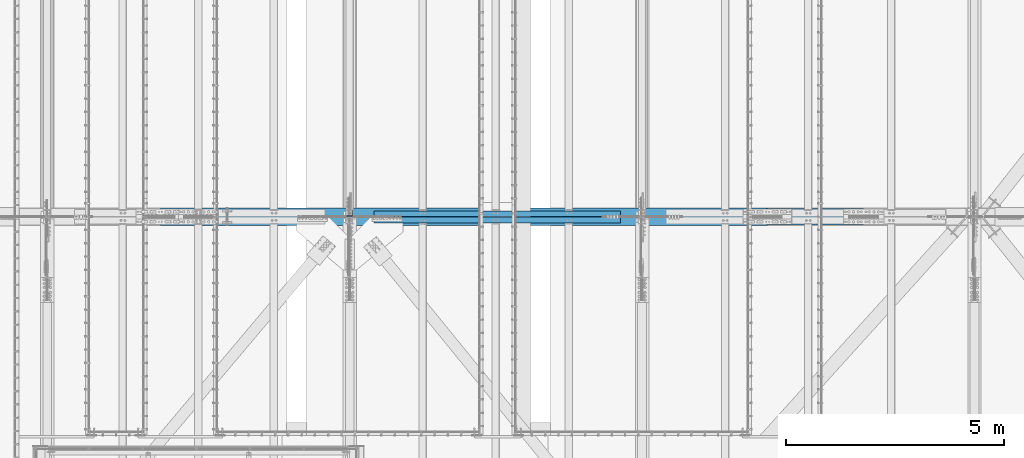
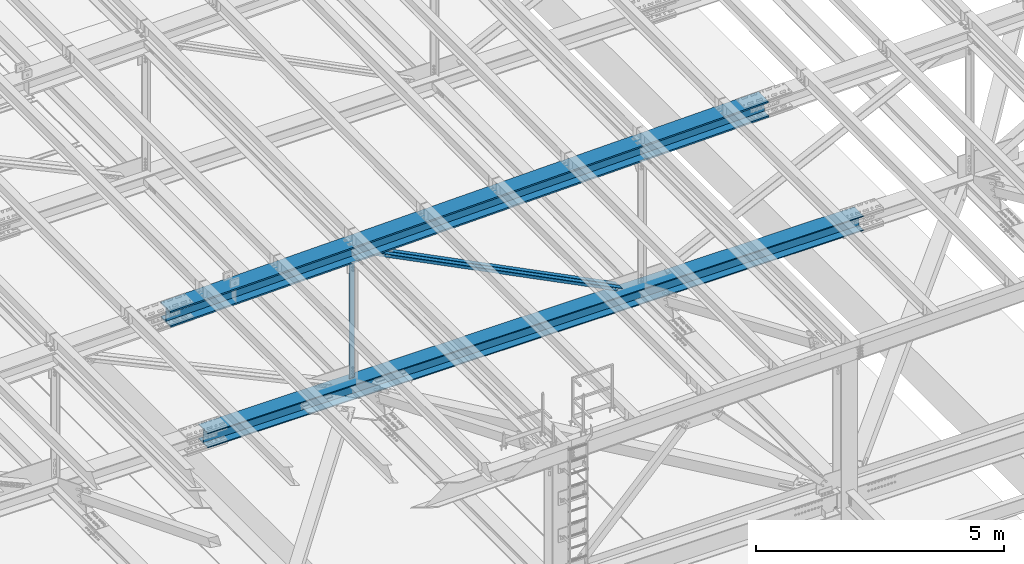
# One storey, part 1825 of 3843: 3 beams, 2 members, 5 elements without a shape of their own.
"""IFC2X3 building model written with IfcOpenShell, lengths in millimetres."""

from ifc_helpers import new_model, si_unit, frame, origin_with_axes, place, context, subcontext, project, spatial, faceted_brep, material, type_object, element, aggregate, save


model = new_model("IFC2X3")

# Units and contexts
model_context = context("Model", 3, precision=1e-05, world=origin_with_axes())
body_context = subcontext(model_context, "Body", "Model", "MODEL_VIEW")
ifc_project = project(units=[si_unit("LENGTHUNIT", "METRE", prefix="MILLI"), si_unit("AREAUNIT", "SQUARE_METRE"), si_unit("VOLUMEUNIT", "CUBIC_METRE"), si_unit("MASSUNIT", "GRAM", prefix="KILO"), si_unit("TIMEUNIT", "SECOND"), si_unit("PLANEANGLEUNIT", "RADIAN"), si_unit("SOLIDANGLEUNIT", "STERADIAN"), si_unit("THERMODYNAMICTEMPERATUREUNIT", "DEGREE_CELSIUS"), si_unit("LUMINOUSINTENSITYUNIT", "LUMEN")], contexts=[model_context])

# Site, building, storey
site_placement = place(None, origin_with_axes())
site = spatial("IfcSite", under=ifc_project, at=site_placement, CompositionType="ELEMENT")
building_placement = place(site_placement, origin_with_axes())
building = spatial("IfcBuilding", under=site, at=building_placement, Name="Undefined", CompositionType="ELEMENT")
storey_placement = place(building_placement, origin_with_axes())
storey = spatial("IfcBuildingStorey", under=building, at=storey_placement, Name="Undefined", CompositionType="ELEMENT", Elevation=0.0)

# Assembly, beam
assembly_1_placement = place(storey_placement, origin_with_axes())
assembly_1 = element("IfcElementAssembly", 1, at=assembly_1_placement, inside=storey, Name="BEAM", AssemblyPlace="NOTDEFINED", PredefinedType="RIGID_FRAME")
ifc_material_1 = material(Name="STEEL/A992")
beam_type_1 = type_object("IfcBeamType", Name="W14X193", PredefinedType="NOTDEFINED")
beam_1_placement = place(assembly_1_placement, frame((51591.6587020663, 33845.5, 45546.4074801041), z_axis=(-0.0216342480057937, 0.0, 0.999765952267441), x_axis=(0.999765952267441, 0.0, 0.0216342480057898)))
beam_1 = element("IfcBeam", 2, at=beam_1_placement, type_object=beam_type_1, material=ifc_material_1, Name="BEAM", ObjectType="W14X193", context=body_context, shape_type="Brep", body=[
    faceted_brep([(6.34999999676074, 200.025000000001, -196.850000000573), (6.3499999967753, 200.025000000001, -160.337500000467), (13916.1085202669, 200.025000000001, -160.337499982867), (13916.1085202304, 200.025000000001, -196.849999982958), (6.3499999967753, 11.1125000000029, -160.337500000467), (13916.1085202669, 11.1125000000029, -160.337499982867), (6.34999999676074, 11.1125000000029, 160.337500000445), (13916.1085205875, 11.1125000000029, 160.337500018017), (6.34999999676074, 200.025000000001, 160.337500000445), (13916.1085205875, 200.025000000001, 160.337500018017), (6.3499999967753, 200.025000000001, 196.850000000544), (13916.108520624, 200.025000000001, 196.850000018108), (6.3499999967753, -200.025000000001, 196.850000000544), (13916.108520624, -200.025000000001, 196.850000018108), (6.34999999676074, -200.025000000001, 160.337500000445), (13916.1085205875, -200.025000000001, 160.337500018017), (6.34999999676074, -11.1125000000029, 160.337500000445), (13916.1085205875, -11.1125000000029, 160.337500018017), (6.3499999967753, -11.1125000000029, -160.337500000467), (13916.1085202669, -11.1125000000029, -160.337499982867), (6.3499999967753, -200.025000000001, -160.337500000467), (13916.1085202669, -200.025000000001, -160.337499982867), (6.34999999676074, -200.025000000001, -196.850000000573), (13916.1085202304, -200.025000000001, -196.849999982958)], [[[0, 1, 2, 3]], [[1, 4, 5, 2]], [[4, 6, 7, 5]], [[6, 8, 9, 7]], [[8, 10, 11, 9]], [[10, 12, 13, 11]], [[12, 14, 15, 13]], [[14, 16, 17, 15]], [[16, 18, 19, 17]], [[18, 20, 21, 19]], [[20, 22, 23, 21]], [[22, 0, 3, 23]], [[5, 7, 9, 11, 13, 15, 17, 19, 21, 23, 3, 2]], [[22, 20, 18, 16, 14, 12, 10, 8, 6, 4, 1, 0]]]),
])
aggregate(assembly_1, [beam_1])

assembly_2_placement = place(storey_placement, origin_with_axes())
assembly_2 = element("IfcElementAssembly", 3, at=assembly_2_placement, inside=storey, Name="BEAM", AssemblyPlace="NOTDEFINED", PredefinedType="RIGID_FRAME")
beam_type_2 = type_object("IfcBeamType", Name="W14X120", PredefinedType="NOTDEFINED")
beam_2_placement = place(assembly_2_placement, frame((52463.7, 33845.5, 42254.220820773), z_axis=(-0.00048281500021403, 0.0, 0.999999883444831), x_axis=(0.999999883444831, 0.0, 0.000482815000217081)))
beam_2 = element("IfcBeam", 4, at=beam_2_placement, type_object=beam_type_2, material=ifc_material_1, Name="BEAM", ObjectType="W14X120", context=body_context, shape_type="Brep", body=[
    faceted_brep([(6.34999999732827, 185.737500000003, -184.1500000003), (6.35000000674336, 185.737500000003, -160.33750000099), (15246.3517777405, 185.737500000003, -160.33750003911), (15246.3517777405, 185.737500000003, -184.150000039139), (6.34999999732827, 7.14375000000291, -160.337500000271), (15246.3517777405, 7.14375000000291, -160.33750003911), (6.34999999732827, 7.14375000000291, 160.337500000249), (15246.3517777405, 7.14375000000291, 160.337499961403), (6.35000000639411, 185.737500000003, 160.337500001014), (15246.3517777405, 185.737500000003, 160.337499961403), (6.34999999734282, 185.737500000003, 184.150000000292), (15246.3517777405, 185.737500000003, 184.149999961453), (6.34999999734282, -185.737500000003, 184.150000000292), (15246.3517777405, -185.737500000003, 184.149999961453), (6.35000000639411, -185.737500000003, 160.337500001014), (15246.3517777405, -185.737500000003, 160.337499961403), (6.34999999732827, -7.14375000000291, 160.337500000249), (15246.3517777405, -7.14375000000291, 160.337499961403), (6.34999999732827, -7.14375000000291, -160.337500000271), (15246.3517777405, -7.14375000000291, -160.33750003911), (6.35000000674336, -185.737500000003, -160.33750000099), (15246.3517777405, -185.737500000003, -160.33750003911), (6.34999999732827, -185.737500000003, -184.1500000003), (15246.3517777405, -185.737500000003, -184.150000039139)], [[[0, 1, 2, 3]], [[1, 4, 5, 2]], [[4, 6, 7, 5]], [[6, 8, 9, 7]], [[8, 10, 11, 9]], [[10, 12, 13, 11]], [[12, 14, 15, 13]], [[14, 16, 17, 15]], [[16, 18, 19, 17]], [[18, 20, 21, 19]], [[20, 22, 23, 21]], [[22, 0, 3, 23]], [[5, 7, 9, 11, 13, 15, 17, 19, 21, 23, 3, 2]], [[22, 20, 18, 16, 14, 12, 10, 8, 6, 4, 1, 0]]]),
])
aggregate(assembly_2, [beam_2])

assembly_3_placement = place(storey_placement, origin_with_axes())
assembly_3 = element("IfcElementAssembly", 5, at=assembly_3_placement, inside=storey, Name="ANGLE", AssemblyPlace="NOTDEFINED", PredefinedType="RIGID_FRAME")
ifc_material_2 = material(Name="STEEL/A572-50")
beam_type_3 = type_object("IfcBeamType", Name="L5X5X3/8", PredefinedType="NOTDEFINED")
beam_3_placement = place(assembly_3_placement, frame((55930.799998912, 33918.525, 45640.3035215003), z_axis=(-1.0, 0.0, 0.0), x_axis=(0.0, 0.0, -1.0)))
beam_3 = element("IfcBeam", 6, at=beam_3_placement, type_object=beam_type_3, material=ifc_material_2, Name="ANGLE", ObjectType="L5X5X3/8", context=body_context, shape_type="Brep", body=[
    faceted_brep([(223.301043988627, 63.5, -63.5), (223.301043988627, 63.5, 63.5), (3175.61295734502, 63.5, 63.5), (3175.61295734502, 63.5, -63.5), (223.301043988627, 53.9749999999985, 63.5), (3175.61295734502, 53.9749999999985, 63.5), (223.301043988627, 53.9749999999985, -53.9749999999985), (3175.61295734502, 53.9749999999985, -53.9749999999985), (223.301043988627, -63.5, -53.9749999999985), (3175.61295734502, -63.5, -53.9749999999985), (223.301043988627, -63.5, -63.5), (3175.61295734502, -63.5, -63.5)], [[[0, 1, 2, 3]], [[1, 4, 5, 2]], [[4, 6, 7, 5]], [[6, 8, 9, 7]], [[8, 10, 11, 9]], [[10, 0, 3, 11]], [[5, 7, 9, 11, 3, 2]], [[10, 8, 6, 4, 1, 0]]]),
])
aggregate(assembly_3, [beam_3])

# Assembly, member
assembly_4_placement = place(storey_placement, origin_with_axes())
assembly_4 = element("IfcElementAssembly", 7, at=assembly_4_placement, inside=storey, Name="ANGLE", AssemblyPlace="NOTDEFINED", PredefinedType="RIGID_FRAME")
member_type = type_object("IfcMemberType", Name="L5X5X3/8", PredefinedType="NOTDEFINED")
member_1_placement = place(assembly_4_placement, frame((55930.799998912, 33918.525, 45640.3035215003), z_axis=(-0.450233343976099, 0.0, -0.892910933952597), x_axis=(0.892910933952598, 0.0, -0.450233343976098)))
member_1 = element("IfcMember", 8, at=member_1_placement, type_object=member_type, material=ifc_material_2, Name="ANGLE", ObjectType="L5X5X3/8", context=body_context, shape_type="Brep", body=[
    faceted_brep([(592.468540349397, 63.5, -63.5000000006548), (592.468540349873, 63.5, 63.4999999991123), (6919.05613815341, 63.5, 63.4999999909778), (6919.05613815294, 63.5, -63.5000000087894), (592.468540349873, 53.9749999999985, 63.4999999991123), (6919.05613815341, 53.9749999999985, 63.4999999909778), (592.46854034943, 53.9749999999985, -53.9750000006752), (6919.05613815297, 53.9749999999985, -53.9750000087952), (592.46854034943, -63.5, -53.9750000006752), (6919.05613815297, -63.5, -53.9750000087952), (592.468540349397, -63.5, -63.5000000006548), (6919.05613815294, -63.5, -63.5000000087894)], [[[0, 1, 2, 3]], [[1, 4, 5, 2]], [[4, 6, 7, 5]], [[6, 8, 9, 7]], [[8, 10, 11, 9]], [[10, 0, 3, 11]], [[5, 7, 9, 11, 3, 2]], [[10, 8, 6, 4, 1, 0]]]),
])
aggregate(assembly_4, [member_1])

assembly_5_placement = place(storey_placement, origin_with_axes())
assembly_5 = element("IfcElementAssembly", 9, at=assembly_5_placement, inside=storey, Name="ANGLE", AssemblyPlace="NOTDEFINED", PredefinedType="RIGID_FRAME")
member_2_placement = place(assembly_5_placement, frame((62636.3999988622, 33772.475, 42259.1323502955), z_axis=(-0.450233343976099, 0.0, -0.892910933952597), x_axis=(-0.892910933952598, 0.0, 0.450233343976097)))
member_2 = element("IfcMember", 10, at=member_2_placement, type_object=member_type, material=ifc_material_2, Name="ANGLE", ObjectType="L5X5X3/8", context=body_context, shape_type="Brep", body=[
    faceted_brep([(590.763412073291, 63.5, -63.4999999991269), (590.763412073291, 63.5, 63.5000000006257), (6917.3510321327, 63.5, 63.5000000087603), (6917.35103213269, 63.5, -63.4999999910069), (590.763412073291, 53.9749999999985, 63.5000000006257), (6917.3510321327, 53.9749999999985, 63.5000000087603), (590.763412073291, 53.9749999999985, -53.9749999991618), (6917.3510321327, 53.9749999999985, -53.9749999910273), (590.763412073291, -63.5, -53.9749999991618), (6917.3510321327, -63.5, -53.9749999910273), (590.763412073291, -63.5, -63.4999999991269), (6917.35103213269, -63.5, -63.4999999910069)], [[[0, 1, 2, 3]], [[1, 4, 5, 2]], [[4, 6, 7, 5]], [[6, 8, 9, 7]], [[8, 10, 11, 9]], [[10, 0, 3, 11]], [[5, 7, 9, 11, 3, 2]], [[10, 8, 6, 4, 1, 0]]]),
])
aggregate(assembly_5, [member_2])

save(model, "model.ifc")
